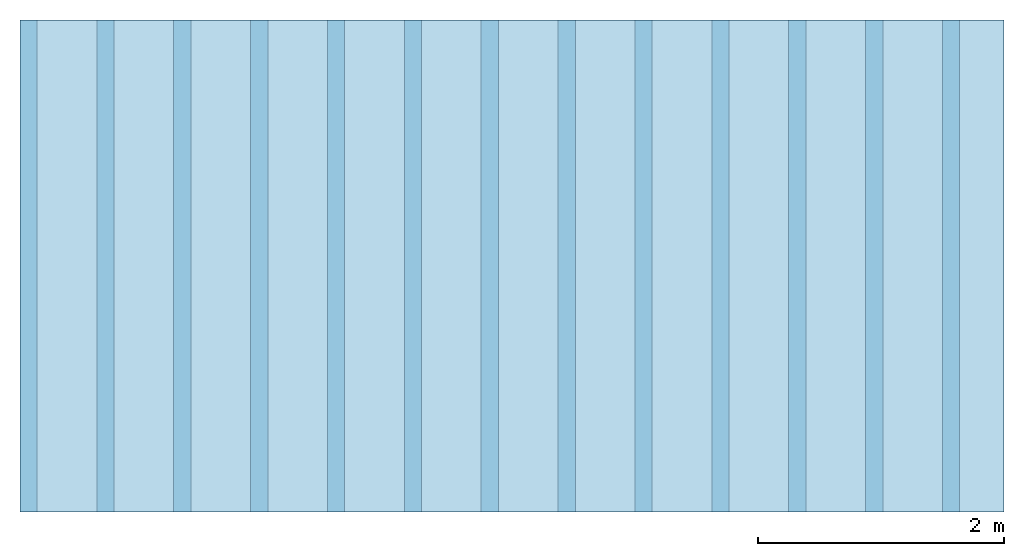
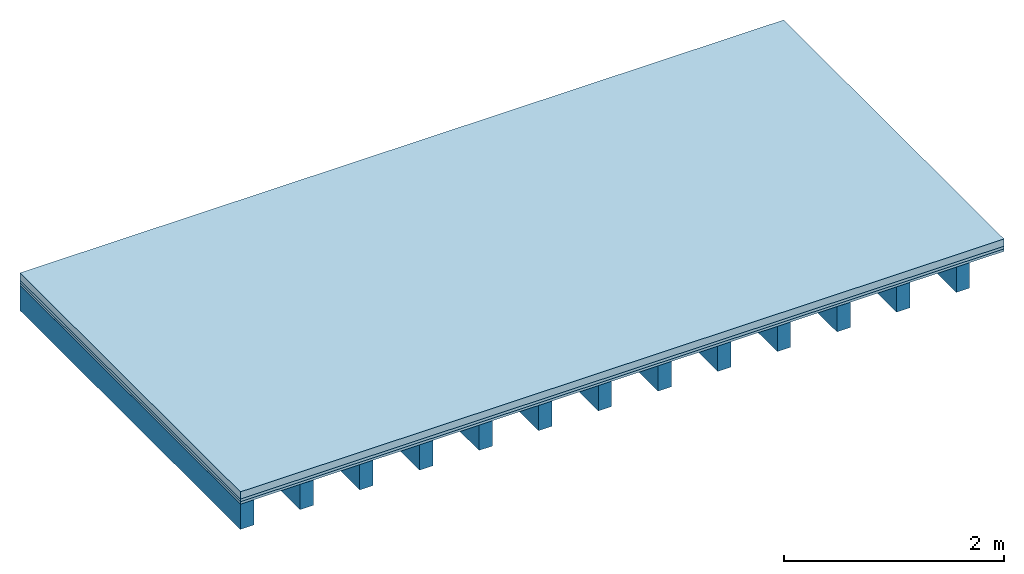
# One storey: 3 plates, 1 member, 1 element without a shape of its own.
"""IFC4 building model written with IfcOpenShell, lengths in metres."""

from ifc_helpers import new_model, si_unit, derived_unit, direction, frame, frame_2d, origin, origin_with_axes, place, context, project, spatial, rectangle, extrude, material, layer, layer_set, type_object, element, aggregate, save


model = new_model("IFC4")

# Units and contexts
plan_context = context("Plan", 3, precision=1e-05, world=origin(), true_north=direction((0.0, 1.0)))
model_context = context("Model", 3, precision=1e-05, world=origin(), true_north=direction((0.0, 1.0)))
ifc_project = project(units=[si_unit("LENGTHUNIT", "METRE"), derived_unit("SOUNDPRESSUREUNIT", [(si_unit("PRESSUREUNIT", "PASCAL", prefix="MICRO"), 0)]), si_unit("ENERGYUNIT", "JOULE", prefix="MEGA"), si_unit("MASSUNIT", "GRAM", prefix="KILO"), derived_unit("THERMALTRANSMITTANCEUNIT", [(si_unit("POWERUNIT", "WATT"), 1), (si_unit("AREAUNIT", "SQUARE_METRE"), -1), (si_unit("THERMODYNAMICTEMPERATUREUNIT", "KELVIN"), -1)]), derived_unit("AREADENSITYUNIT", [(si_unit("MASSUNIT", "GRAM", prefix="KILO"), 1), (si_unit("AREAUNIT", "SQUARE_METRE"), -1)]), derived_unit("USERDEFINED", [(si_unit("ENERGYUNIT", "JOULE", prefix="MEGA"), 1), (si_unit("AREAUNIT", "SQUARE_METRE"), -1)])], contexts=[plan_context, model_context])

# Site, building, storey
site = spatial("IfcSite", under=ifc_project)
building_placement = place(None, origin())
building = spatial("IfcBuilding", under=site, at=building_placement)
storey_placement = place(building_placement, origin())
storey = spatial("IfcBuildingStorey", under=building, at=storey_placement)

# Slab, member, plates
ifc_material_1 = material(Name="Cement screed", Category="04.006")
ifc_layer_1 = layer(ifc_material_1, 0.08, Name="On-material")
ifc_material_2 = material()
ifc_layer_2 = layer(ifc_material_2, 0.03, Name="Impact sound insulation")
ifc_material_3 = material(Category="07.001")
ifc_layer_3 = layer(ifc_material_3, 0.027, Name="Sub-floor")
ifc_material_4 = material(Name="of the art")
ifc_layer_4 = layer(ifc_material_4, 0.0, Name="Bond")
ifc_layer_5 = layer(None, 0.28, Name="Supporting structure")
ifc_layer_set = layer_set([ifc_layer_1, ifc_layer_2, ifc_layer_3, ifc_layer_4, ifc_layer_5])
slab_type = type_object("IfcSlabType", Name="A0090", PredefinedType="NOTDEFINED", material=ifc_layer_set)
slab_placement = place(None, frame((0.0, 0.0, 0.0), z_axis=(0.0, 0.0, -1.0), x_axis=(1.0, 0.0, 0.0)))
slab = element("IfcSlab", 1, at=slab_placement, inside=storey, type_object=slab_type, material=ifc_layer_set, Name="Slab #1")
ifc_material_5 = material()
member_placement = place(slab_placement, origin())
member = element("IfcMember", 2, at=member_placement, material=ifc_material_5, Name="Supporting structure", context=plan_context, shape_type="SweptSolid", body=[
    extrude(rectangle(XDim=0.14, YDim=0.28, at=frame_2d((0.07, 0.14), x_axis=(1.0, 0.0))), frame((0.0, 4.0, 0.137), z_axis=(0.0, -1.0, 0.0), x_axis=(1.0, 0.0, 0.0)), (0.0, 0.0, 1.0), 4.0),
    extrude(rectangle(XDim=0.14, YDim=0.28, at=frame_2d((0.07, 0.14), x_axis=(1.0, 0.0))), frame((0.625, 4.0, 0.137), z_axis=(0.0, -1.0, 0.0), x_axis=(1.0, 0.0, 0.0)), (0.0, 0.0, 1.0), 4.0),
    extrude(rectangle(XDim=0.14, YDim=0.28, at=frame_2d((0.07, 0.14), x_axis=(1.0, 0.0))), frame((1.25, 4.0, 0.137), z_axis=(0.0, -1.0, 0.0), x_axis=(1.0, 0.0, 0.0)), (0.0, 0.0, 1.0), 4.0),
    extrude(rectangle(XDim=0.14, YDim=0.28, at=frame_2d((0.07, 0.14), x_axis=(1.0, 0.0))), frame((1.875, 4.0, 0.137), z_axis=(0.0, -1.0, 0.0), x_axis=(1.0, 0.0, 0.0)), (0.0, 0.0, 1.0), 4.0),
    extrude(rectangle(XDim=0.14, YDim=0.28, at=frame_2d((0.07, 0.14), x_axis=(1.0, 0.0))), frame((2.5, 4.0, 0.137), z_axis=(0.0, -1.0, 0.0), x_axis=(1.0, 0.0, 0.0)), (0.0, 0.0, 1.0), 4.0),
    extrude(rectangle(XDim=0.14, YDim=0.28, at=frame_2d((0.07, 0.14), x_axis=(1.0, 0.0))), frame((3.125, 4.0, 0.137), z_axis=(0.0, -1.0, 0.0), x_axis=(1.0, 0.0, 0.0)), (0.0, 0.0, 1.0), 4.0),
    extrude(rectangle(XDim=0.14, YDim=0.28, at=frame_2d((0.07, 0.14), x_axis=(1.0, 0.0))), frame((3.75, 4.0, 0.137), z_axis=(0.0, -1.0, 0.0), x_axis=(1.0, 0.0, 0.0)), (0.0, 0.0, 1.0), 4.0),
    extrude(rectangle(XDim=0.14, YDim=0.28, at=frame_2d((0.07, 0.14), x_axis=(1.0, 0.0))), frame((4.375, 4.0, 0.137), z_axis=(0.0, -1.0, 0.0), x_axis=(1.0, 0.0, 0.0)), (0.0, 0.0, 1.0), 4.0),
    extrude(rectangle(XDim=0.14, YDim=0.28, at=frame_2d((0.07, 0.14), x_axis=(1.0, 0.0))), frame((5.0, 4.0, 0.137), z_axis=(0.0, -1.0, 0.0), x_axis=(1.0, 0.0, 0.0)), (0.0, 0.0, 1.0), 4.0),
    extrude(rectangle(XDim=0.14, YDim=0.28, at=frame_2d((0.07, 0.14), x_axis=(1.0, 0.0))), frame((5.625, 4.0, 0.137), z_axis=(0.0, -1.0, 0.0), x_axis=(1.0, 0.0, 0.0)), (0.0, 0.0, 1.0), 4.0),
    extrude(rectangle(XDim=0.14, YDim=0.28, at=frame_2d((0.07, 0.14), x_axis=(1.0, 0.0))), frame((6.25, 4.0, 0.137), z_axis=(0.0, -1.0, 0.0), x_axis=(1.0, 0.0, 0.0)), (0.0, 0.0, 1.0), 4.0),
    extrude(rectangle(XDim=0.14, YDim=0.28, at=frame_2d((0.07, 0.14), x_axis=(1.0, 0.0))), frame((6.875, 4.0, 0.137), z_axis=(0.0, -1.0, 0.0), x_axis=(1.0, 0.0, 0.0)), (0.0, 0.0, 1.0), 4.0),
    extrude(rectangle(XDim=0.14, YDim=0.28, at=frame_2d((0.07, 0.14), x_axis=(1.0, 0.0))), frame((7.5, 4.0, 0.137), z_axis=(0.0, -1.0, 0.0), x_axis=(1.0, 0.0, 0.0)), (0.0, 0.0, 1.0), 4.0),
])
plate_1_placement = place(slab_placement, origin())
plate_1 = element("IfcPlate", 3, at=plate_1_placement, material=ifc_material_1, Name="On-material", context=plan_context, shape_type="SweptSolid", body=[
    extrude(rectangle(XDim=8.0, YDim=4.0, at=frame_2d((4.0, 2.0), x_axis=(1.0, 0.0))), origin_with_axes(), (0.0, 0.0, 1.0), 0.08),
])
plate_2_placement = place(slab_placement, origin())
plate_2 = element("IfcPlate", 4, at=plate_2_placement, material=ifc_material_2, Name="Impact sound insulation", context=plan_context, shape_type="SweptSolid", body=[
    extrude(rectangle(XDim=8.0, YDim=4.0, at=frame_2d((4.0, 2.0), x_axis=(1.0, 0.0))), frame((0.0, 0.0, 0.08), z_axis=(0.0, 0.0, 1.0), x_axis=(1.0, 0.0, 0.0)), (0.0, 0.0, 1.0), 0.03),
])
plate_3_placement = place(slab_placement, origin())
plate_3 = element("IfcPlate", 5, at=plate_3_placement, material=ifc_material_3, Name="Sub-floor", context=plan_context, shape_type="SweptSolid", body=[
    extrude(rectangle(XDim=8.0, YDim=4.0, at=frame_2d((4.0, 2.0), x_axis=(1.0, 0.0))), frame((0.0, 0.0, 0.11), z_axis=(0.0, 0.0, 1.0), x_axis=(1.0, 0.0, 0.0)), (0.0, 0.0, 1.0), 0.027),
])
aggregate(slab, [plate_1, plate_2, plate_3, member])

save(model, "model.ifc")
